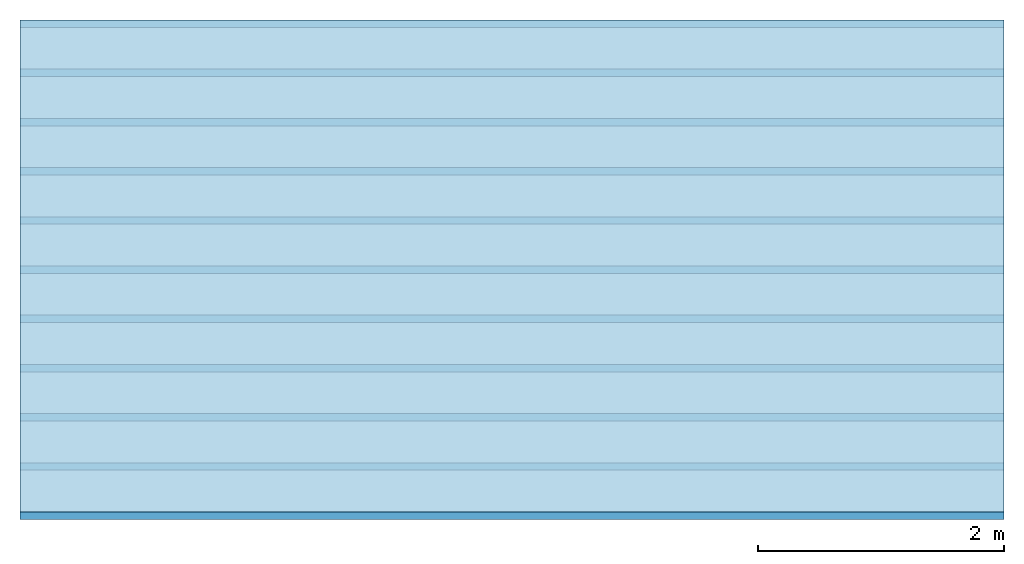
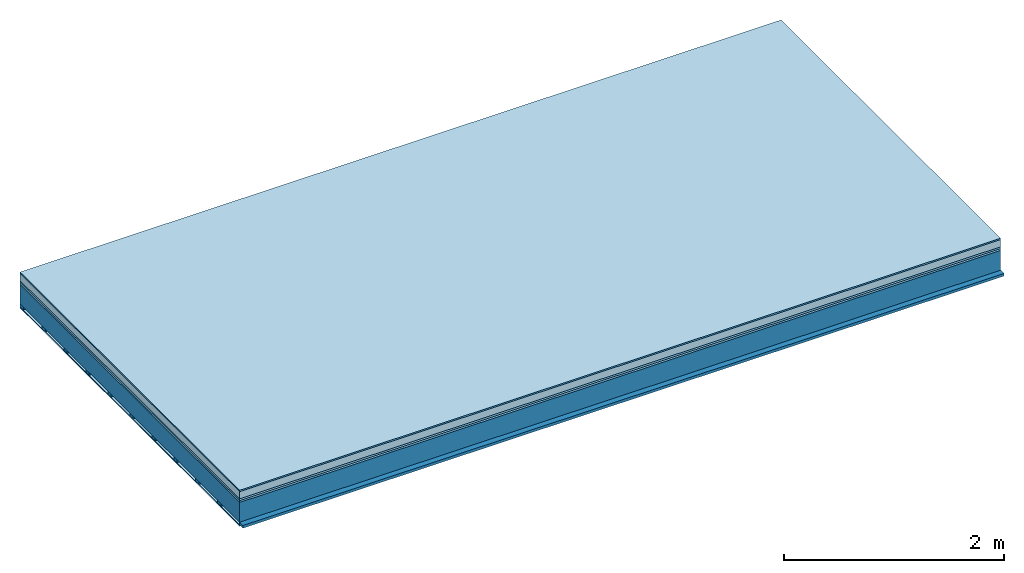
# One storey: 6 plates, 2 members, 1 element without a shape of its own.
"""IFC4 building model written with IfcOpenShell, lengths in metres."""

from ifc_helpers import new_model, si_unit, derived_unit, direction, frame, frame_2d, origin, origin_with_axes, place, context, project, spatial, rectangle, extrude, material, layer, layer_set, type_object, element, aggregate, save


model = new_model("IFC4")

# Units and contexts
plan_context = context("Plan", 3, precision=1e-05, world=origin(), true_north=direction((0.0, 1.0)))
model_context = context("Model", 3, precision=1e-05, world=origin(), true_north=direction((0.0, 1.0)))
ifc_project = project(units=[si_unit("LENGTHUNIT", "METRE"), derived_unit("SOUNDPRESSUREUNIT", [(si_unit("PRESSUREUNIT", "PASCAL", prefix="MICRO"), 0)]), si_unit("ENERGYUNIT", "JOULE", prefix="MEGA"), si_unit("MASSUNIT", "GRAM", prefix="KILO"), derived_unit("THERMALTRANSMITTANCEUNIT", [(si_unit("POWERUNIT", "WATT"), 1), (si_unit("AREAUNIT", "SQUARE_METRE"), -1), (si_unit("THERMODYNAMICTEMPERATUREUNIT", "KELVIN"), -1)]), derived_unit("AREADENSITYUNIT", [(si_unit("MASSUNIT", "GRAM", prefix="KILO"), 1), (si_unit("AREAUNIT", "SQUARE_METRE"), -1)]), derived_unit("USERDEFINED", [(si_unit("ENERGYUNIT", "JOULE", prefix="MEGA"), 1), (si_unit("AREAUNIT", "SQUARE_METRE"), -1)])], contexts=[plan_context, model_context])

# Site, building, storey
site = spatial("IfcSite", under=ifc_project)
building_placement = place(None, origin())
building = spatial("IfcBuilding", under=site, at=building_placement)
storey_placement = place(building_placement, origin())
storey = spatial("IfcBuildingStorey", under=building, at=storey_placement)

# Slab, members, plates
ifc_material_1 = material(Category="11.013")
ifc_layer_1 = layer(ifc_material_1, 0.015, Name="Flooring")
ifc_material_2 = material(Name="Cement screed", Category="04.006")
ifc_layer_2 = layer(ifc_material_2, 0.08, Name="On-material")
ifc_material_3 = material(Name="Wood fiber generic product", Category="10.009")
ifc_layer_3 = layer(ifc_material_3, 0.02, Name="Impact sound insulation")
ifc_material_4 = material(Category="10.004")
ifc_layer_4 = layer(ifc_material_4, 0.02, Name="Additional insulation")
ifc_material_5 = material(Name="no composite action")
ifc_layer_5 = layer(ifc_material_5, 0.0, Name="Bond")
ifc_layer_6 = layer(None, 0.22, Name="Supporting structure")
ifc_material_6 = material(Name="of the art")
ifc_layer_7 = layer(ifc_material_6, 0.0, Name="Bond")
ifc_layer_8 = layer(None, 0.03, Name="Battens / profiles")
ifc_material_7 = material(Name="Plasterboard type A", Category="03.008")
ifc_layer_9 = layer(ifc_material_7, 0.0125, Name="Ceiling covering 1st layer")
ifc_material_8 = material(Category="04.001")
ifc_layer_10 = layer(ifc_material_8, 0.003, Name="Surface / treatment")
ifc_layer_set = layer_set([ifc_layer_1, ifc_layer_2, ifc_layer_3, ifc_layer_4, ifc_layer_5, ifc_layer_6, ifc_layer_7, ifc_layer_8, ifc_layer_9, ifc_layer_10])
slab_type = type_object("IfcSlabType", Name="A2146", PredefinedType="NOTDEFINED", material=ifc_layer_set)
slab_placement = place(None, frame((0.0, 0.0, 0.0), z_axis=(0.0, 0.0, -1.0), x_axis=(1.0, 0.0, 0.0)))
slab = element("IfcSlab", 1, at=slab_placement, inside=storey, type_object=slab_type, material=ifc_layer_set, Name="Slab #1")
ifc_material_9 = material(Name="Solid timber panel")
member_1_placement = place(slab_placement, origin())
member_1 = element("IfcMember", 2, at=member_1_placement, material=ifc_material_9, Name="Supporting structure", context=plan_context, shape_type="SweptSolid", body=[
    extrude(rectangle(XDim=1.0, YDim=0.22, at=frame_2d((0.5, 0.11), x_axis=(1.0, 0.0))), frame((0.0, 4.0, 0.135), z_axis=(0.0, -1.0, 0.0), x_axis=(1.0, 0.0, 0.0)), (0.0, 0.0, 1.0), 4.0),
    extrude(rectangle(XDim=1.0, YDim=0.22, at=frame_2d((0.5, 0.11), x_axis=(1.0, 0.0))), frame((1.0, 4.0, 0.135), z_axis=(0.0, -1.0, 0.0), x_axis=(1.0, 0.0, 0.0)), (0.0, 0.0, 1.0), 4.0),
    extrude(rectangle(XDim=1.0, YDim=0.22, at=frame_2d((0.5, 0.11), x_axis=(1.0, 0.0))), frame((2.0, 4.0, 0.135), z_axis=(0.0, -1.0, 0.0), x_axis=(1.0, 0.0, 0.0)), (0.0, 0.0, 1.0), 4.0),
    extrude(rectangle(XDim=1.0, YDim=0.22, at=frame_2d((0.5, 0.11), x_axis=(1.0, 0.0))), frame((3.0, 4.0, 0.135), z_axis=(0.0, -1.0, 0.0), x_axis=(1.0, 0.0, 0.0)), (0.0, 0.0, 1.0), 4.0),
    extrude(rectangle(XDim=1.0, YDim=0.22, at=frame_2d((0.5, 0.11), x_axis=(1.0, 0.0))), frame((4.0, 4.0, 0.135), z_axis=(0.0, -1.0, 0.0), x_axis=(1.0, 0.0, 0.0)), (0.0, 0.0, 1.0), 4.0),
    extrude(rectangle(XDim=1.0, YDim=0.22, at=frame_2d((0.5, 0.11), x_axis=(1.0, 0.0))), frame((5.0, 4.0, 0.135), z_axis=(0.0, -1.0, 0.0), x_axis=(1.0, 0.0, 0.0)), (0.0, 0.0, 1.0), 4.0),
    extrude(rectangle(XDim=1.0, YDim=0.22, at=frame_2d((0.5, 0.11), x_axis=(1.0, 0.0))), frame((6.0, 4.0, 0.135), z_axis=(0.0, -1.0, 0.0), x_axis=(1.0, 0.0, 0.0)), (0.0, 0.0, 1.0), 4.0),
    extrude(rectangle(XDim=1.0, YDim=0.22, at=frame_2d((0.5, 0.11), x_axis=(1.0, 0.0))), frame((7.0, 4.0, 0.135), z_axis=(0.0, -1.0, 0.0), x_axis=(1.0, 0.0, 0.0)), (0.0, 0.0, 1.0), 4.0),
])
ifc_material_10 = material()
member_2_placement = place(slab_placement, origin())
member_2 = element("IfcMember", 3, at=member_2_placement, material=ifc_material_10, Name="Battens / profiles", context=plan_context, shape_type="SweptSolid", body=[
    extrude(rectangle(XDim=0.06, YDim=0.03, at=frame_2d((0.03, 0.015), x_axis=(1.0, 0.0))), frame((0.0, 0.0, 0.355), z_axis=(1.0, 0.0, 0.0), x_axis=(0.0, 1.0, 0.0)), (0.0, 0.0, 1.0), 8.0),
    extrude(rectangle(XDim=0.06, YDim=0.03, at=frame_2d((0.03, 0.015), x_axis=(1.0, 0.0))), frame((0.0, 0.4, 0.355), z_axis=(1.0, 0.0, 0.0), x_axis=(0.0, 1.0, 0.0)), (0.0, 0.0, 1.0), 8.0),
    extrude(rectangle(XDim=0.06, YDim=0.03, at=frame_2d((0.03, 0.015), x_axis=(1.0, 0.0))), frame((0.0, 0.8, 0.355), z_axis=(1.0, 0.0, 0.0), x_axis=(0.0, 1.0, 0.0)), (0.0, 0.0, 1.0), 8.0),
    extrude(rectangle(XDim=0.06, YDim=0.03, at=frame_2d((0.03, 0.015), x_axis=(1.0, 0.0))), frame((0.0, 1.2, 0.355), z_axis=(1.0, 0.0, 0.0), x_axis=(0.0, 1.0, 0.0)), (0.0, 0.0, 1.0), 8.0),
    extrude(rectangle(XDim=0.06, YDim=0.03, at=frame_2d((0.03, 0.015), x_axis=(1.0, 0.0))), frame((0.0, 1.6, 0.355), z_axis=(1.0, 0.0, 0.0), x_axis=(0.0, 1.0, 0.0)), (0.0, 0.0, 1.0), 8.0),
    extrude(rectangle(XDim=0.06, YDim=0.03, at=frame_2d((0.03, 0.015), x_axis=(1.0, 0.0))), frame((0.0, 2.0, 0.355), z_axis=(1.0, 0.0, 0.0), x_axis=(0.0, 1.0, 0.0)), (0.0, 0.0, 1.0), 8.0),
    extrude(rectangle(XDim=0.06, YDim=0.03, at=frame_2d((0.03, 0.015), x_axis=(1.0, 0.0))), frame((0.0, 2.4, 0.355), z_axis=(1.0, 0.0, 0.0), x_axis=(0.0, 1.0, 0.0)), (0.0, 0.0, 1.0), 8.0),
    extrude(rectangle(XDim=0.06, YDim=0.03, at=frame_2d((0.03, 0.015), x_axis=(1.0, 0.0))), frame((0.0, 2.8, 0.355), z_axis=(1.0, 0.0, 0.0), x_axis=(0.0, 1.0, 0.0)), (0.0, 0.0, 1.0), 8.0),
    extrude(rectangle(XDim=0.06, YDim=0.03, at=frame_2d((0.03, 0.015), x_axis=(1.0, 0.0))), frame((0.0, 3.2, 0.355), z_axis=(1.0, 0.0, 0.0), x_axis=(0.0, 1.0, 0.0)), (0.0, 0.0, 1.0), 8.0),
    extrude(rectangle(XDim=0.06, YDim=0.03, at=frame_2d((0.03, 0.015), x_axis=(1.0, 0.0))), frame((0.0, 3.6, 0.355), z_axis=(1.0, 0.0, 0.0), x_axis=(0.0, 1.0, 0.0)), (0.0, 0.0, 1.0), 8.0),
    extrude(rectangle(XDim=0.06, YDim=0.03, at=frame_2d((0.03, 0.015), x_axis=(1.0, 0.0))), frame((0.0, 4.0, 0.355), z_axis=(1.0, 0.0, 0.0), x_axis=(0.0, 1.0, 0.0)), (0.0, 0.0, 1.0), 8.0),
])
plate_1_placement = place(slab_placement, origin())
plate_1 = element("IfcPlate", 4, at=plate_1_placement, material=ifc_material_1, Name="Flooring", context=plan_context, shape_type="SweptSolid", body=[
    extrude(rectangle(XDim=8.0, YDim=4.0, at=frame_2d((4.0, 2.0), x_axis=(1.0, 0.0))), origin_with_axes(), (0.0, 0.0, 1.0), 0.015),
])
plate_2_placement = place(slab_placement, origin())
plate_2 = element("IfcPlate", 5, at=plate_2_placement, material=ifc_material_2, Name="On-material", context=plan_context, shape_type="SweptSolid", body=[
    extrude(rectangle(XDim=8.0, YDim=4.0, at=frame_2d((4.0, 2.0), x_axis=(1.0, 0.0))), frame((0.0, 0.0, 0.015), z_axis=(0.0, 0.0, 1.0), x_axis=(1.0, 0.0, 0.0)), (0.0, 0.0, 1.0), 0.08),
])
plate_3_placement = place(slab_placement, origin())
plate_3 = element("IfcPlate", 6, at=plate_3_placement, material=ifc_material_3, Name="Impact sound insulation", context=plan_context, shape_type="SweptSolid", body=[
    extrude(rectangle(XDim=8.0, YDim=4.0, at=frame_2d((4.0, 2.0), x_axis=(1.0, 0.0))), frame((0.0, 0.0, 0.095), z_axis=(0.0, 0.0, 1.0), x_axis=(1.0, 0.0, 0.0)), (0.0, 0.0, 1.0), 0.02),
])
plate_4_placement = place(slab_placement, origin())
plate_4 = element("IfcPlate", 7, at=plate_4_placement, material=ifc_material_4, Name="Additional insulation", context=plan_context, shape_type="SweptSolid", body=[
    extrude(rectangle(XDim=8.0, YDim=4.0, at=frame_2d((4.0, 2.0), x_axis=(1.0, 0.0))), frame((0.0, 0.0, 0.115), z_axis=(0.0, 0.0, 1.0), x_axis=(1.0, 0.0, 0.0)), (0.0, 0.0, 1.0), 0.02),
])
plate_5_placement = place(slab_placement, origin())
plate_5 = element("IfcPlate", 8, at=plate_5_placement, material=ifc_material_7, Name="Ceiling covering 1st layer", context=plan_context, shape_type="SweptSolid", body=[
    extrude(rectangle(XDim=8.0, YDim=4.0, at=frame_2d((4.0, 2.0), x_axis=(1.0, 0.0))), frame((0.0, 0.0, 0.385), z_axis=(0.0, 0.0, 1.0), x_axis=(1.0, 0.0, 0.0)), (0.0, 0.0, 1.0), 0.0125),
])
plate_6_placement = place(slab_placement, origin())
plate_6 = element("IfcPlate", 9, at=plate_6_placement, material=ifc_material_8, Name="Surface / treatment", context=plan_context, shape_type="SweptSolid", body=[
    extrude(rectangle(XDim=8.0, YDim=4.0, at=frame_2d((4.0, 2.0), x_axis=(1.0, 0.0))), frame((0.0, 0.0, 0.3975), z_axis=(0.0, 0.0, 1.0), x_axis=(1.0, 0.0, 0.0)), (0.0, 0.0, 1.0), 0.003),
])
aggregate(slab, [plate_1, plate_2, plate_3, plate_4, member_1, member_2, plate_5, plate_6])

save(model, "model.ifc")
